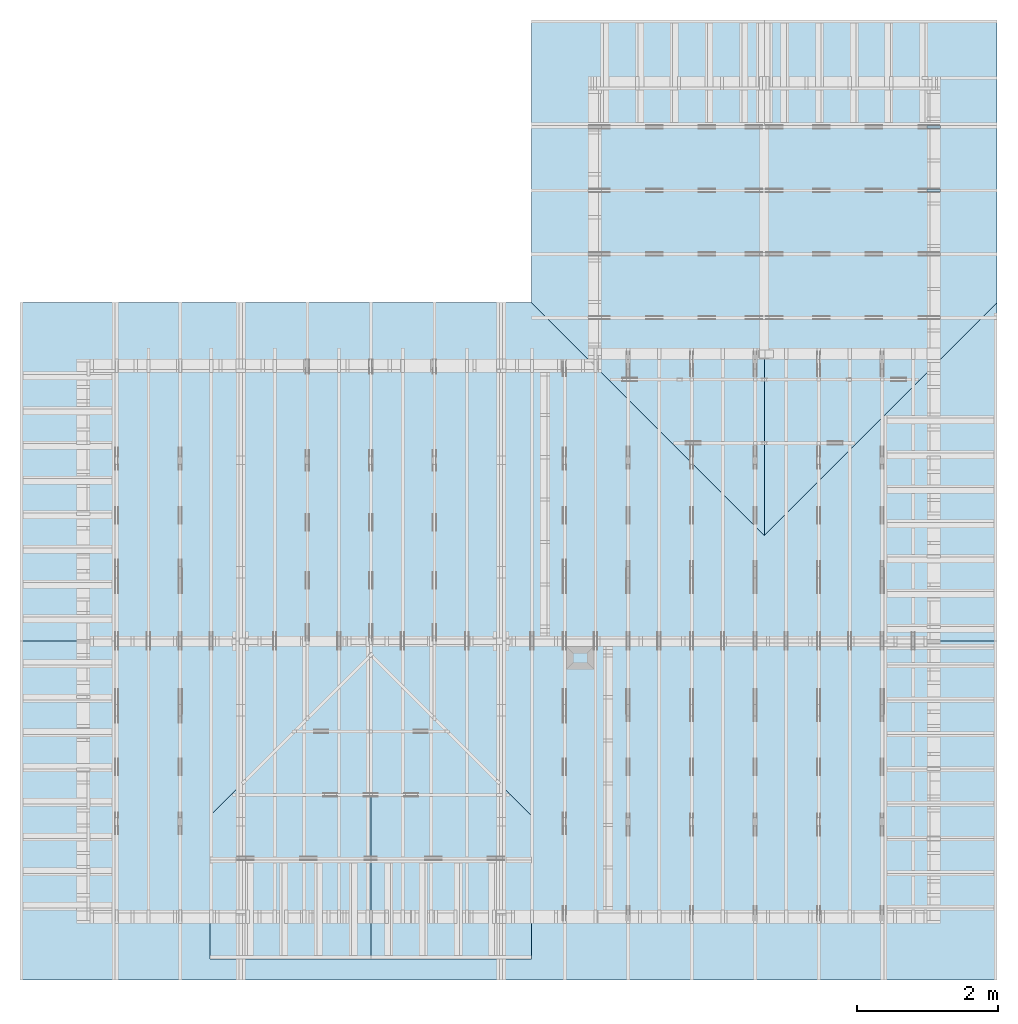
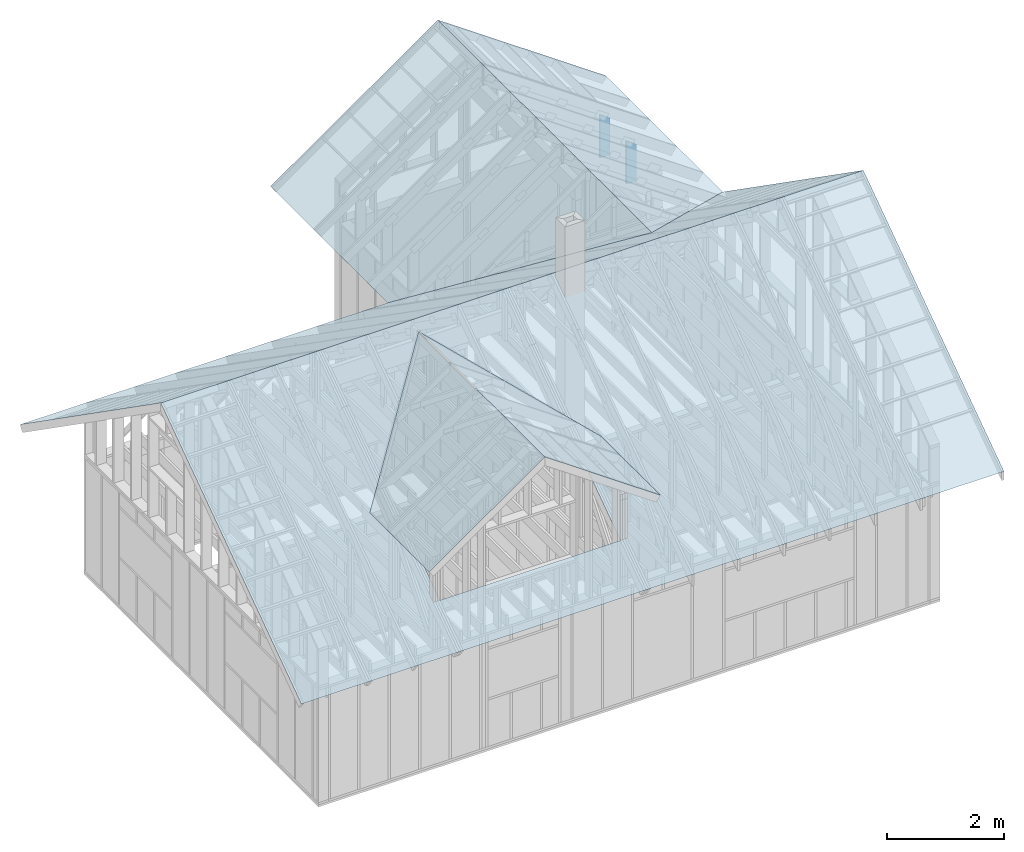
# One storey, part 43 of 70: 6 slabs, 2 members, 2 elements without a shape of their own.
"""IFC2X3 building model written with IfcOpenShell, lengths in millimetres."""

from ifc_helpers import new_model, si_unit, frame, origin, origin_with_axes, origin_2d, place, context, project, spatial, faceted_brep, element, aggregate, save


model = new_model("IFC2X3")

# Units and contexts
model_context = context("Model", 3, precision=1e-05, world=origin())
plan_context = context("Plan", 2, precision=1e-05, world=origin_2d())
ifc_project = project(units=[si_unit("LENGTHUNIT", "METRE", prefix="MILLI"), si_unit("AREAUNIT", "SQUARE_METRE"), si_unit("VOLUMEUNIT", "CUBIC_METRE"), si_unit("SOLIDANGLEUNIT", "STERADIAN"), si_unit("PLANEANGLEUNIT", "RADIAN"), si_unit("MASSUNIT", "GRAM"), si_unit("TIMEUNIT", "SECOND"), si_unit("THERMODYNAMICTEMPERATUREUNIT", "DEGREE_CELSIUS"), si_unit("LUMINOUSINTENSITYUNIT", "LUMEN")], contexts=[model_context, plan_context])

# Site, building, storey
site_placement = place(None, origin_with_axes())
site = spatial("IfcSite", under=ifc_project, at=site_placement, CompositionType="ELEMENT")
building_placement = place(site_placement, origin_with_axes())
building = spatial("IfcBuilding", under=site, at=building_placement, Name="Layout 1", CompositionType="ELEMENT")
storey_placement = place(building_placement, origin_with_axes())
storey = spatial("IfcBuildingStorey", under=building, at=storey_placement, Name="Storey 1", CompositionType="ELEMENT", Elevation=0.0)

# Assembly, member
assembly_1_placement = place(storey_placement, frame((12000.0, 10405.0, 1.3776821480501744e-15), z_axis=(1.2246063538223773e-16, 1.0, 6.123031769111886e-17), x_axis=(-1.0, 1.2246063538223773e-16, 0.0)))
assembly_1 = element("IfcElementAssembly", 1, at=assembly_1_placement, inside=storey, Name="T10", AssemblyPlace="FACTORY", PredefinedType="TRUSS")
member_1_placement = place(assembly_1_placement, frame((195.0, -1.1939911949768178e-14, -45.0), z_axis=(0.0, 0.0, 1.0), x_axis=(6.123031769111886e-17, 1.0, 0.0)))
member_1 = element("IfcMember", 2, at=member_1_placement, Name="E2", context=model_context, shape_type="Brep", body=[
    faceted_brep([(761.9489551902298, 195.0000000000146, 45.0), (0.0, 195.0000000000146, 45.0), (1.1939911949768178e-14, 0.0, 45.0), (898.489425140906, 0.0, 45.0), (0.0, 195.0000000000146, 0.0), (761.9489551902298, 195.0000000000146, 9.330875318142772e-14), (898.489425140906, 0.0, 1.1002958588697687e-13), (1.1939911949768178e-14, 0.0, 1.462169203776584e-30), (1.1939911949768178e-14, 0.0, 0.0), (1.4695276245868527e-14, -3.3742366240998092e-31, 45.0), (3.8575100145404884e-14, 195.0, 45.0), (3.5819735849304535e-14, 195.0, -2.193253805664876e-30), (898.489425140906, 6.111174466091852e-10, 7.337620909297005e-30), (898.489425140906, 6.111202019734813e-10, 45.0), (1.1939911949766304e-14, 2.7553642961003473e-15, 45.0), (1.1939911949768178e-14, -1.5924907264090874e-30, 9.750871309819471e-47), (761.94895519023, 195.0000000000148, 1.8932661725304283e-29), (761.94895519023, 195.0000000000148, 45.0), (898.4894251409063, 6.11407813266851e-10, 45.0), (898.4894251409063, 6.11407813266851e-10, 1.8932661725304283e-29), (0.0, 195.0, 0.0), (0.0, 195.0, 45.0), (761.9489551902298, 195.00000000001467, 45.0), (761.9489551902298, 195.00000000001467, 3.1554436208840472e-30)], [[[0, 1, 2, 3]], [[4, 5, 6, 7]], [[8, 9, 10, 11]], [[12, 13, 14, 15]], [[16, 17, 18, 19]], [[20, 21, 22, 23]]]),
])
aggregate(assembly_1, [member_1])

assembly_2_placement = place(storey_placement, frame((12000.0, 11305.0, 1.3776821480501744e-15), z_axis=(1.2246063538223773e-16, 1.0, 6.123031769111886e-17), x_axis=(-1.0, 1.2246063538223773e-16, 0.0)))
assembly_2 = element("IfcElementAssembly", 3, at=assembly_2_placement, inside=storey, Name="T10", AssemblyPlace="FACTORY", PredefinedType="TRUSS")
member_2_placement = place(assembly_2_placement, frame((195.0, -1.1939911949768178e-14, -45.0), z_axis=(0.0, 0.0, 1.0), x_axis=(6.123031769111886e-17, 1.0, 0.0)))
member_2 = element("IfcMember", 4, at=member_2_placement, Name="E2", context=model_context, shape_type="Brep", body=[
    faceted_brep([(761.9489551902298, 195.0000000000146, 45.0), (0.0, 195.0000000000146, 45.0), (1.1939911949768178e-14, 0.0, 45.0), (898.489425140906, 0.0, 45.0), (0.0, 195.0000000000146, 0.0), (761.9489551902298, 195.0000000000146, 9.330875318142772e-14), (898.489425140906, 0.0, 1.1002958588697687e-13), (1.1939911949768178e-14, 0.0, 1.462169203776584e-30), (1.1939911949768178e-14, 0.0, 0.0), (1.4695276245868527e-14, -3.3742366240998092e-31, 45.0), (3.8575100145404884e-14, 195.0, 45.0), (3.5819735849304535e-14, 195.0, -2.193253805664876e-30), (898.489425140906, 6.111174466091852e-10, 7.337620909297005e-30), (898.489425140906, 6.111202019734813e-10, 45.0), (1.1939911949766304e-14, 2.7553642961003473e-15, 45.0), (1.1939911949768178e-14, -1.5924907264090874e-30, 9.750871309819471e-47), (761.94895519023, 195.0000000000148, 1.8932661725304283e-29), (761.94895519023, 195.0000000000148, 45.0), (898.4894251409063, 6.11407813266851e-10, 45.0), (898.4894251409063, 6.11407813266851e-10, 1.8932661725304283e-29), (0.0, 195.0, 0.0), (0.0, 195.0, 45.0), (761.9489551902298, 195.00000000001467, 45.0), (761.9489551902298, 195.00000000001467, 3.1554436208840472e-30)], [[[0, 1, 2, 3]], [[4, 5, 6, 7]], [[8, 9, 10, 11]], [[12, 13, 14, 15]], [[16, 17, 18, 19]], [[20, 21, 22, 23]]]),
])
aggregate(assembly_2, [member_2])

# Slabs
slab_1_placement = place(storey_placement, frame((4991.432579868179, 1545.694865058848, 2082.307196286246), z_axis=(0.0, -0.5735764363510462, 0.819152044288992), x_axis=(1.0, 0.0, 0.0)))
element("IfcSlab", 5, at=slab_1_placement, inside=storey, Name="Roof surface 1", PredefinedType="ROOF", context=model_context, shape_type="Brep", body=[
    faceted_brep([(7808.567420131821, 2996.1533418029157, -3.213097280191931e-13), (-6034.985970461456, 2996.1533418029157, -3.213097280191931e-13), (-6034.985970461457, -2863.564684252074, -3.213097280191931e-13), (7808.567420131821, -2863.564684252074, -3.213097280191931e-13), (713.5674201321626, 588.7494365386319, -3.213097280191931e-13), (713.5674201318188, -1886.94501324291, -3.213097280191931e-13), (-2841.432579868181, -1886.94501324291, -3.213097280191931e-13), (-2841.4325798681966, 588.7494365386319, -3.213097280191931e-13), (-1063.9325798682112, 2758.6762680624997, -3.213097280191931e-13)], [[[0, 1, 2, 3], [4, 5, 6, 7, 8]]], orient=[[True, False]]),
])
slab_2_placement = place(storey_placement, frame((6260.482203135574, 5975.0, 2417.9202648746614), z_axis=(7.024053483582875e-17, 0.5735764363510462, 0.819152044288992), x_axis=(-1.0, 1.2246063538223775e-16, 1.2325951644078312e-32)))
element("IfcSlab", 6, at=slab_2_placement, inside=storey, Name="Roof surface 5", PredefinedType="ROOF", context=model_context, shape_type="Brep", body=[
    faceted_brep([(7304.03559372885, 2411.029812803875, 1.304175667394135e-12), (-6539.5177968644275, 2411.029812803875, 1.304175667394135e-12), (-6539.517796864426, -3448.688213251113, 1.304175667394135e-12), (-3239.517796864424, 579.8679296616915, 1.304175667394135e-12), (60.48220313557431, -3448.688213251113, 1.304175667394135e-12), (7304.03559372885, -3448.688213251113, 1.304175667394135e-12)], [[[0, 1, 2, 3, 4, 5]]]),
])
slab_3_placement = place(storey_placement, frame((7849.999999999999, 9699.999999999998, 1595.1764074782513), z_axis=(-0.5735764363510462, 1.0536080225374313e-16, 0.819152044288992), x_axis=(-1.8369095307335664e-16, -1.0, 1.2325951644078312e-32)))
element("IfcSlab", 7, at=slab_3_placement, inside=storey, Name="Roof surface 7", PredefinedType="ROOF", context=model_context, shape_type="Brep", body=[
    faceted_brep([(4199.999999999998, 2014.2780714564014, 2.27373675443232e-13), (-3100.000000000002, 2014.2780714564014, 2.27373675443232e-13), (-3100.000000000002, -2014.2780714564005, 2.27373675443232e-13), (899.9999999999982, -2014.2780714564005, 2.27373675443232e-13)], [[[0, 1, 2, 3]]]),
])
slab_4_placement = place(storey_placement, frame((11149.999999999998, 9700.0, 1595.1764074782545), z_axis=(0.5735764363510462, -3.5120267417914375e-17, 0.819152044288992), x_axis=(6.123031769111888e-17, 1.0, 6.162975822039156e-33)))
element("IfcSlab", 8, at=slab_4_placement, inside=storey, Name="Roof surface 8", PredefinedType="ROOF", context=model_context, shape_type="Brep", body=[
    faceted_brep([(3100.0, 2014.2780714564033, -5.048709793414476e-28), (-4199.999999999999, 2014.2780714564033, -5.048709793414476e-28), (-900.0, -2014.278071456405, -5.048709793414476e-28), (3100.0, -2014.278071456405, -5.048709793414476e-28)], [[[0, 1, 2, 3]]]),
])
slab_5_placement = place(storey_placement, frame((5066.250000000194, 893.5684181200418, 2867.257565031317), z_axis=(0.5735764363510462, -3.5120267417914375e-17, 0.819152044288992), x_axis=(6.123031769111888e-17, 1.0, 6.162975822039156e-33)))
element("IfcSlab", 9, at=slab_5_placement, inside=storey, Name="Roof surface 10", PredefinedType="ROOF", context=model_context, shape_type="Brep", body=[
    faceted_brep([(2911.9017514531197, 1390.1570629523449, -4.547473508864703e-13), (-1393.5684181200415, 1390.1570629523449, -4.547473508864703e-13), (-1393.5684181200415, -1390.157062951871, -4.547473508864703e-13), (634.4017514535024, -1390.157062951871, -4.547473508864703e-13)], [[[0, 1, 2, 3]]]),
])
slab_6_placement = place(storey_placement, frame((2788.7499999999873, 1273.1517514535553, 2867.2575650314443), z_axis=(-0.5735764363510462, 1.0536080225374313e-16, 0.819152044288992), x_axis=(-1.8369095307335664e-16, -1.0, 1.2325951644078312e-32)))
element("IfcSlab", 10, at=slab_6_placement, inside=storey, Name="Roof surface 12", PredefinedType="ROOF", context=model_context, shape_type="Brep", body=[
    faceted_brep([(1773.1517514535549, 1390.157062952123, 1.5146129380243427e-28), (-2532.3184181202164, 1390.157062952123, 1.5146129380243427e-28), (-254.81841812023413, -1390.1570629520938, 1.5146129380243427e-28), (1773.151751453556, -1390.1570629520938, 1.5146129380243427e-28)], [[[0, 1, 2, 3]]]),
])

save(model, "model.ifc")
